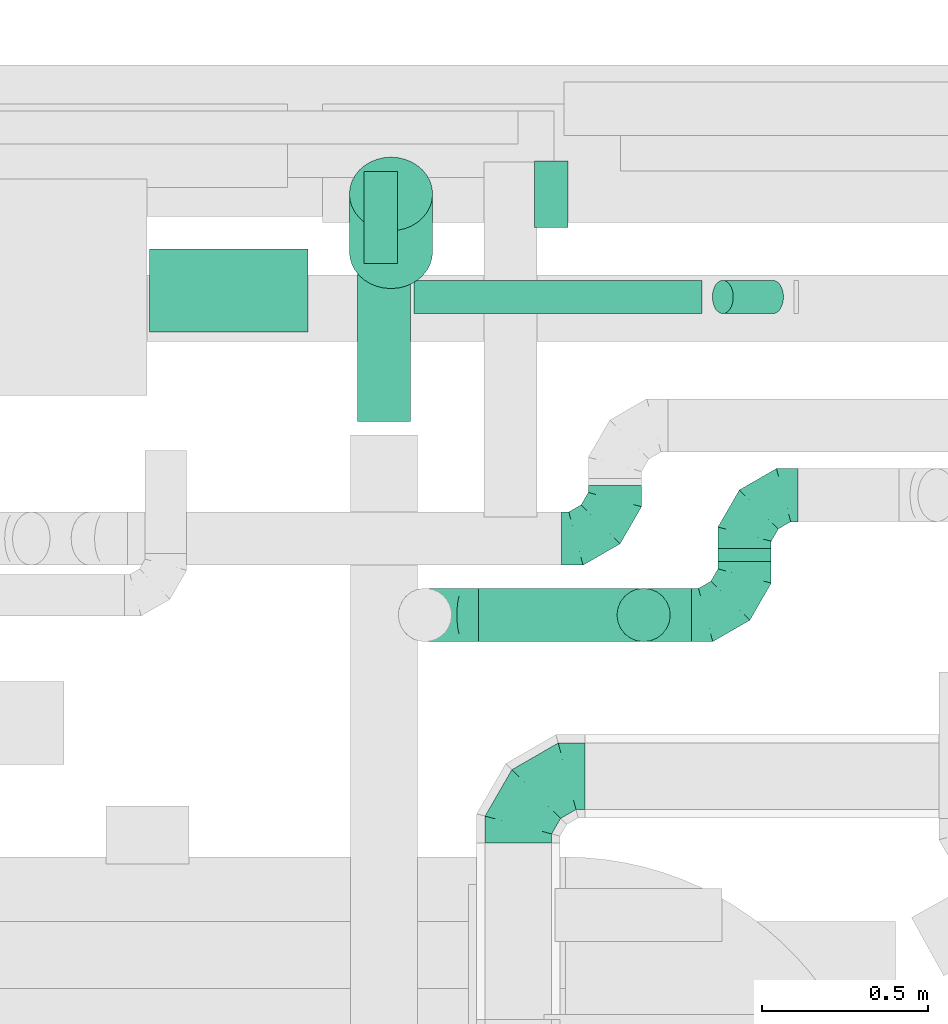
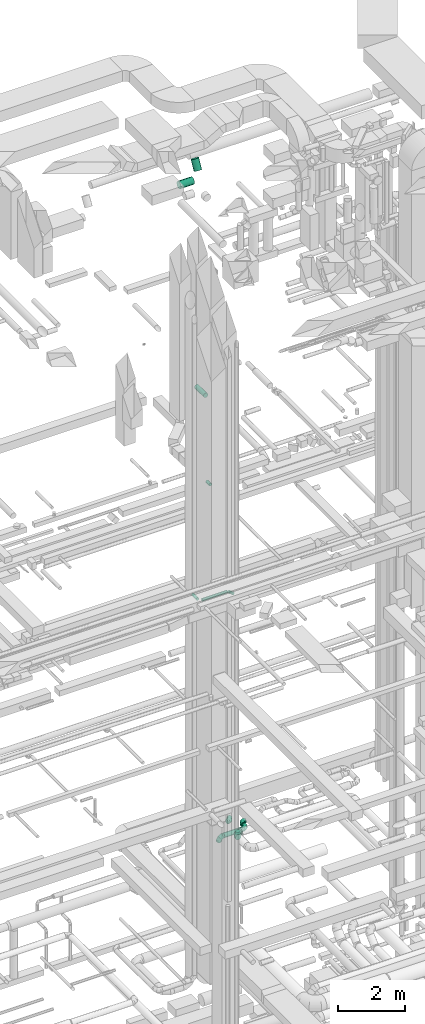
# One storey, part 281 of 337: 9 flow segments, 6 flow fittings.
"""IFC2X3 building model written with IfcOpenShell, lengths in millimetres."""

from ifc_helpers import new_model, entity, si_unit, converted_unit, derived_unit, direction, frame, origin, origin_2d_with_axis, place, context, subcontext, project, spatial, circle, extrude, faceted_brep, source, transform, mapped, material, type_object, type_shapes, element, save


model = new_model("IFC2X3")

# Units and contexts
model_context = context("Model", 3, precision=0.01, world=origin(), true_north=direction((6.12303176911189e-17, 1.0)))
body_context = subcontext(model_context, "Body", "Model", "MODEL_VIEW")
ifc_project = project(units=[si_unit("LENGTHUNIT", "METRE", prefix="MILLI"), si_unit("AREAUNIT", "SQUARE_METRE"), si_unit("VOLUMEUNIT", "CUBIC_METRE"), converted_unit("PLANEANGLEUNIT", "DEGREE", entity("IfcRatioMeasure", 0.0174532925199433), si_unit("PLANEANGLEUNIT", "RADIAN"), dimensions=[0, 0, 0, 0, 0, 0, 0]), si_unit("MASSUNIT", "GRAM", prefix="KILO"), derived_unit("MASSDENSITYUNIT", [(si_unit("MASSUNIT", "GRAM", prefix="KILO"), 1), (si_unit("LENGTHUNIT", "METRE"), -3)]), derived_unit("MOMENTOFINERTIAUNIT", [(si_unit("LENGTHUNIT", "METRE"), 4)]), si_unit("TIMEUNIT", "SECOND"), si_unit("FREQUENCYUNIT", "HERTZ"), si_unit("THERMODYNAMICTEMPERATUREUNIT", "DEGREE_CELSIUS"), derived_unit("THERMALTRANSMITTANCEUNIT", [(si_unit("MASSUNIT", "GRAM", prefix="KILO"), 1), (si_unit("THERMODYNAMICTEMPERATUREUNIT", "KELVIN"), -1), (si_unit("TIMEUNIT", "SECOND"), -3)]), derived_unit("VOLUMETRICFLOWRATEUNIT", [(si_unit("LENGTHUNIT", "METRE"), 3), (si_unit("TIMEUNIT", "SECOND"), -1)]), derived_unit("MASSFLOWRATEUNIT", [(si_unit("MASSUNIT", "GRAM", prefix="KILO"), 1), (si_unit("TIMEUNIT", "SECOND"), -1)]), derived_unit("ROTATIONALFREQUENCYUNIT", [(si_unit("TIMEUNIT", "SECOND"), -1)]), si_unit("ELECTRICCURRENTUNIT", "AMPERE"), si_unit("ELECTRICVOLTAGEUNIT", "VOLT"), si_unit("POWERUNIT", "WATT"), si_unit("FORCEUNIT", "NEWTON", prefix="KILO"), si_unit("ILLUMINANCEUNIT", "LUX"), si_unit("LUMINOUSFLUXUNIT", "LUMEN"), si_unit("LUMINOUSINTENSITYUNIT", "CANDELA"), derived_unit("USERDEFINED", [(si_unit("MASSUNIT", "GRAM", prefix="KILO"), -1), (si_unit("LENGTHUNIT", "METRE"), -2), (si_unit("TIMEUNIT", "SECOND"), 3), (si_unit("LUMINOUSFLUXUNIT", "LUMEN"), 1)]), derived_unit("LINEARVELOCITYUNIT", [(si_unit("LENGTHUNIT", "METRE"), 1), (si_unit("TIMEUNIT", "SECOND"), -1)]), si_unit("PRESSUREUNIT", "PASCAL"), derived_unit("USERDEFINED", [(si_unit("LENGTHUNIT", "METRE"), -2), (si_unit("MASSUNIT", "GRAM", prefix="KILO"), 1), (si_unit("TIMEUNIT", "SECOND"), -2)]), derived_unit("LINEARFORCEUNIT", [(si_unit("MASSUNIT", "GRAM", prefix="KILO"), 1), (si_unit("LENGTHUNIT", "METRE"), 1), (si_unit("TIMEUNIT", "SECOND"), -2), (si_unit("LENGTHUNIT", "METRE"), -1)]), derived_unit("PLANARFORCEUNIT", [(si_unit("MASSUNIT", "GRAM", prefix="KILO"), 1), (si_unit("LENGTHUNIT", "METRE"), 1), (si_unit("TIMEUNIT", "SECOND"), -2), (si_unit("LENGTHUNIT", "METRE"), -2)])], contexts=[model_context])

# Site, building, storey
site_placement = place(None, origin())
site = spatial("IfcSite", under=ifc_project, at=site_placement, CompositionType="ELEMENT")
building_placement = place(site_placement, origin())
building = spatial("IfcBuilding", under=site, at=building_placement, CompositionType="ELEMENT")
storey_placement = place(building_placement, origin())
storey = spatial("IfcBuildingStorey", under=building, at=storey_placement, CompositionType="ELEMENT", Elevation=0.0)

# Flow segments
duct_segment_type = type_object("IfcDuctSegmentType", PredefinedType="NOTDEFINED")
flow_segment_1_placement = place(storey_placement, frame((49059.87, 19353.19, 11348.4)))
element("IfcFlowSegment", 1, at=flow_segment_1_placement, inside=storey, type_object=duct_segment_type, context=body_context, shape_type="SweptSolid", body=[
    extrude(circle(Radius=50.0, at=origin_2d_with_axis()), frame((0.0, 51.6, 51.6), z_axis=(1.0, 0.0, 0.0), x_axis=(0.0, 1.0, 0.0)), (0.0, 0.0, 1.0), 864.588142746948),
])
flow_segment_2_placement = place(storey_placement, frame((49954.33, 19353.19, 11215.06)))
element("IfcFlowSegment", 2, at=flow_segment_2_placement, inside=storey, type_object=duct_segment_type, context=body_context, shape_type="SweptSolid", body=[
    extrude(circle(Radius=50.0, at=origin_2d_with_axis()), frame((33.06, 51.6, 162.65), z_axis=(0.777145961456967, 0.0, -0.629320391049843), x_axis=(0.0, -1.0, 0.0)), (0.0, 0.0, 1.0), 194.176285493916),
])
flow_segment_3_placement = place(storey_placement, frame((48908.27, 19504.79, 11348.4)))
element("IfcFlowSegment", 3, at=flow_segment_3_placement, inside=storey, type_object=duct_segment_type, context=body_context, shape_type="SweptSolid", body=[
    extrude(circle(Radius=50.0, at=origin_2d_with_axis()), frame((51.6, 0.0, 51.6), z_axis=(0.0, 1.0, 0.0), x_axis=(-1.0, 0.0, 0.0)), (0.0, 0.0, 1.0), 276.269796034324),
])
flow_segment_4_placement = place(storey_placement, frame((48888.15, 19030.52, 19073.4)))
element("IfcFlowSegment", 4, at=flow_segment_4_placement, inside=storey, type_object=duct_segment_type, context=body_context, shape_type="SweptSolid", body=[
    extrude(circle(Radius=80.0, at=origin_2d_with_axis()), frame((81.6, 0.0, 81.6), z_axis=(0.0, 1.0, 0.0), x_axis=(1.0, 0.0, 0.0)), (0.0, 0.0, 1.0), 539.99999999999),
])
flow_segment_5_placement = place(storey_placement, frame((49420.41, 19613.88, 15298.4)))
element("IfcFlowSegment", 5, at=flow_segment_5_placement, inside=storey, type_object=duct_segment_type, context=body_context, shape_type="SweptSolid", body=[
    extrude(circle(Radius=50.0, at=origin_2d_with_axis()), frame((51.6, 0.0, 51.6), z_axis=(0.0, 1.0, 0.0), x_axis=(-1.0, 0.0, 0.0)), (0.0, 0.0, 1.0), 200.000000000007),
])
flow_segment_6_placement = place(storey_placement, frame((49971.32, 18609.53, 3188.4)))
element("IfcFlowSegment", 6, at=flow_segment_6_placement, inside=storey, type_object=duct_segment_type, context=body_context, shape_type="SweptSolid", body=[
    extrude(circle(Radius=80.0, at=origin_2d_with_axis()), frame((81.6, 0.0, 81.6), z_axis=(0.0, 1.0, 0.0), x_axis=(-1.0, 0.0, 0.0)), (0.0, 0.0, 1.0), 40.0000000000169),
])
flow_segment_7_placement = place(storey_placement, frame((49252.92, 18367.93, 3188.4)))
element("IfcFlowSegment", 7, at=flow_segment_7_placement, inside=storey, type_object=duct_segment_type, context=body_context, shape_type="SweptSolid", body=[
    extrude(circle(Radius=80.0, at=origin_2d_with_axis()), frame((0.0, 81.6, 81.6), z_axis=(1.0, 0.0, 0.0), x_axis=(0.0, 1.0, 0.0)), (0.0, 0.0, 1.0), 639.999999999984),
])
flow_segment_8_placement = place(storey_placement, frame((48265.7, 19297.39, 26748.4)))
element("IfcFlowSegment", 8, at=flow_segment_8_placement, inside=storey, type_object=duct_segment_type, context=body_context, shape_type="SweptSolid", body=[
    extrude(circle(Radius=125.0, at=origin_2d_with_axis()), frame((0.0, 126.6, 126.6), z_axis=(1.0, 0.0, 0.0), x_axis=(0.0, 1.0, 0.0)), (0.0, 0.0, 1.0), 475.000000000005),
])
flow_segment_9_placement = place(storey_placement, frame((48864.11, 19428.49, 27036.19)))
element("IfcFlowSegment", 9, at=flow_segment_9_placement, inside=storey, type_object=duct_segment_type, context=body_context, shape_type="SweptSolid", body=[
    extrude(circle(Radius=125.0, at=origin_2d_with_axis()), frame((126.6, 112.15, 59.92), z_axis=(0.0, 0.46662609244127, 0.884454685019527), x_axis=(1.0, 0.0, 0.0)), (0.0, 0.0, 1.0), 372.214126997912),
])

# Flow fittings
ifc_material = material()
duct_fitting_type_1 = type_object("IfcDuctFittingType", PredefinedType="NOTDEFINED", material=ifc_material)
shared_shape_1 = source(origin(), body_context, "Body", "Brep", [
    faceted_brep([(-160.0, 0.0, -80.0), (-160.0, -20.71, -77.27), (-160.0, -40.0, -69.28), (-160.0, -56.57, -56.57), (-160.0, -69.28, -40.0), (-160.0, -77.27, -20.71), (-160.0, -80.0, 0.0), (-160.0, -77.27, 20.71), (-160.0, -69.28, 40.0), (-160.0, -56.57, 56.57), (-160.0, -40.0, 69.28), (-160.0, -20.71, 77.27), (-160.0, 0.0, 80.0), (-160.0, 20.71, 77.27), (-160.0, 40.0, 69.28), (-160.0, 56.57, 56.57), (-160.0, 69.28, 40.0), (-160.0, 77.27, 20.71), (-160.0, 80.0, 0.0), (-160.0, 77.27, -20.71), (-160.0, 69.28, -40.0), (-160.0, 56.57, -56.57), (-160.0, 40.0, -69.28), (-160.0, 20.71, -77.27), (-122.68, 20.71, 77.27), (-127.85, 40.0, 69.28), (-117.13, 0.0, 80.0), (-132.29, 56.57, 56.57), (-137.83, 77.27, 20.71), (-138.56, 80.0, 0.0), (-135.69, 69.28, 40.0), (-135.69, 69.28, -40.0), (-132.29, 56.57, -56.57), (-137.83, 77.27, -20.71), (-122.68, 20.71, -77.27), (-117.13, 0.0, -80.0), (-127.85, 40.0, -69.28), (-111.58, -20.71, -77.27), (-106.41, -40.0, -69.28), (-101.97, -56.57, -56.57), (-98.56, -69.28, -40.0), (-96.42, -77.27, -20.71), (-95.69, -80.0, 0.0), (-96.42, -77.27, 20.71), (-98.56, -69.28, 40.0), (-101.97, -56.57, 56.57), (-106.41, -40.0, 69.28), (-111.58, -20.71, 77.27), (-58.03, 58.03, 77.27), (-72.15, 72.15, 69.28), (-42.87, 42.87, 80.0), (-84.28, 84.28, 56.57), (-93.59, 93.59, 40.0), (-99.44, 99.44, 20.71), (-101.44, 101.44, 0.0), (-99.44, 99.44, -20.71), (-93.59, 93.59, -40.0), (-84.28, 84.28, -56.57), (-58.03, 58.03, -77.27), (-42.87, 42.87, -80.0), (-72.15, 72.15, -69.28), (-27.71, 27.71, -77.27), (-13.59, 13.59, -69.28), (-1.46, 1.46, -56.57), (7.85, -7.85, -40.0), (13.7, -13.7, -20.71), (15.69, -15.69, 0.0), (13.7, -13.7, 20.71), (7.85, -7.85, 40.0), (-1.46, 1.46, 56.57), (-13.59, 13.59, 69.28), (-27.71, 27.71, 77.27), (-20.71, 122.68, 77.27), (-40.0, 127.85, 69.28), (0.0, 117.13, 80.0), (-56.57, 132.29, 56.57), (-69.28, 135.69, 40.0), (-77.27, 137.83, 20.71), (-80.0, 138.56, 0.0), (-77.27, 137.83, -20.71), (-69.28, 135.69, -40.0), (-56.57, 132.29, -56.57), (-20.71, 122.68, -77.27), (0.0, 117.13, -80.0), (-40.0, 127.85, -69.28), (20.71, 111.58, -77.27), (40.0, 106.41, -69.28), (56.57, 101.97, -56.57), (69.28, 98.56, -40.0), (77.27, 96.42, -20.71), (80.0, 95.69, 0.0), (77.27, 96.42, 20.71), (69.28, 98.56, 40.0), (56.57, 101.97, 56.57), (40.0, 106.41, 69.28), (20.71, 111.58, 77.27), (-20.71, 160.0, -77.27), (-40.0, 160.0, -69.28), (-56.57, 160.0, -56.57), (-69.28, 160.0, -40.0), (-77.27, 160.0, -20.71), (-80.0, 160.0, 0.0), (-77.27, 160.0, 20.71), (-69.28, 160.0, 40.0), (-56.57, 160.0, 56.57), (-40.0, 160.0, 69.28), (-20.71, 160.0, 77.27), (0.0, 160.0, 80.0), (20.71, 160.0, 77.27), (40.0, 160.0, 69.28), (56.57, 160.0, 56.57), (69.28, 160.0, 40.0), (77.27, 160.0, 20.71), (80.0, 160.0, 0.0), (77.27, 160.0, -20.71), (69.28, 160.0, -40.0), (56.57, 160.0, -56.57), (40.0, 160.0, -69.28), (20.71, 160.0, -77.27), (0.0, 160.0, -80.0)], [[[0, 1, 2, 3, 4, 5, 6, 7, 8, 9, 10, 11, 12, 13, 14, 15, 16, 17, 18, 19, 20, 21, 22, 23]], [[24, 25, 14, 13]], [[26, 24, 13, 12]], [[14, 25, 27, 15]], [[28, 29, 18, 17]], [[30, 28, 17, 16]], [[15, 27, 30, 16]], [[20, 31, 32, 21]], [[33, 31, 20, 19]], [[18, 29, 33, 19]], [[34, 35, 0, 23]], [[36, 34, 23, 22]], [[32, 36, 22, 21]], [[1, 0, 35, 37]], [[2, 1, 37, 38]], [[3, 2, 38, 39]], [[5, 4, 40, 41]], [[6, 5, 41, 42]], [[39, 40, 4, 3]], [[6, 42, 43, 7]], [[7, 43, 44, 8]], [[8, 44, 45, 9]], [[9, 45, 46, 10]], [[10, 46, 47, 11]], [[26, 12, 11, 47]], [[48, 49, 25, 24]], [[50, 48, 24, 26]], [[27, 25, 49, 51]], [[52, 53, 28, 30]], [[51, 52, 30, 27]], [[29, 28, 53, 54]], [[55, 56, 31, 33]], [[54, 55, 33, 29]], [[32, 31, 56, 57]], [[58, 59, 35, 34]], [[60, 58, 34, 36]], [[57, 60, 36, 32]], [[37, 35, 59, 61]], [[38, 37, 61, 62]], [[39, 38, 62, 63]], [[41, 40, 64, 65]], [[42, 41, 65, 66]], [[63, 64, 40, 39]], [[43, 42, 66, 67]], [[44, 43, 67, 68]], [[68, 69, 45, 44]], [[46, 45, 69, 70]], [[47, 46, 70, 71]], [[26, 47, 71, 50]], [[72, 73, 49, 48]], [[74, 72, 48, 50]], [[51, 49, 73, 75]], [[76, 77, 53, 52]], [[75, 76, 52, 51]], [[54, 53, 77, 78]], [[79, 80, 56, 55]], [[78, 79, 55, 54]], [[57, 56, 80, 81]], [[82, 83, 59, 58]], [[84, 82, 58, 60]], [[81, 84, 60, 57]], [[61, 59, 83, 85]], [[62, 61, 85, 86]], [[63, 62, 86, 87]], [[65, 64, 88, 89]], [[66, 65, 89, 90]], [[87, 88, 64, 63]], [[67, 66, 90, 91]], [[68, 67, 91, 92]], [[92, 93, 69, 68]], [[70, 69, 93, 94]], [[71, 70, 94, 95]], [[50, 71, 95, 74]], [[96, 97, 98, 99, 100, 101, 102, 103, 104, 105, 106, 107, 108, 109, 110, 111, 112, 113, 114, 115, 116, 117, 118, 119]], [[72, 74, 107, 106]], [[73, 72, 106, 105]], [[75, 73, 105, 104]], [[77, 76, 103, 102]], [[78, 77, 102, 101]], [[75, 104, 103, 76]], [[78, 101, 100, 79]], [[79, 100, 99, 80]], [[80, 99, 98, 81]], [[84, 97, 96, 82]], [[82, 96, 119, 83]], [[84, 81, 98, 97]], [[118, 117, 86, 85]], [[119, 118, 85, 83]], [[116, 87, 86, 117]], [[88, 115, 114, 89]], [[89, 114, 113, 90]], [[115, 88, 87, 116]], [[112, 111, 92, 91]], [[113, 112, 91, 90]], [[111, 110, 93, 92]], [[95, 94, 109, 108]], [[74, 95, 108, 107]], [[110, 109, 94, 93]]]),
])
type_shapes(duct_fitting_type_1, [shared_shape_1])
for number, where in (
    (10, (49663.34, 18679.11, 3550.0)),
    (11, (50052.92, 18449.53, 3270.0)),
):
    element("IfcFlowFitting", number, at=place(storey_placement, frame(where)), inside=storey, type_object=duct_fitting_type_1, material=ifc_material, context=body_context, shape_type="MappedRepresentation", body=[
        mapped(shared_shape_1, transform((0.0, 0.0, 0.0), scale=1.0)),
    ])
for number, where, z_axis, x_axis in (
    (12, (50052.92, 18809.53, 3270.0), (0.0, 0.0, 1.0), (-1.0, 0.0, 0.0)),
    (13, (49092.92, 18449.53, 3270.0), (0.0, -1.0, 0.0), (-1.0, 0.0, 0.0)),
):
    element("IfcFlowFitting", number, at=place(storey_placement, frame(where, z_axis=z_axis, x_axis=x_axis)), inside=storey, type_object=duct_fitting_type_1, material=ifc_material, context=body_context, shape_type="MappedRepresentation", body=[
        mapped(shared_shape_1, transform((0.0, 0.0, 0.0), scale=1.0)),
    ])
duct_fitting_type_2 = type_object("IfcDuctFittingType", PredefinedType="NOTDEFINED", material=ifc_material)
shared_shape_2 = source(origin(), body_context, "Body", "Brep", [
    faceted_brep([(-200.0, 0.0, -100.0), (-200.0, -25.88, -96.59), (-200.0, -50.0, -86.6), (-200.0, -70.71, -70.71), (-200.0, -86.6, -50.0), (-200.0, -96.59, -25.88), (-200.0, -100.0, 0.0), (-200.0, -96.59, 25.88), (-200.0, -86.6, 50.0), (-200.0, -70.71, 70.71), (-200.0, -50.0, 86.6), (-200.0, -25.88, 96.59), (-200.0, 0.0, 100.0), (-200.0, 25.88, 96.59), (-200.0, 50.0, 86.6), (-200.0, 70.71, 70.71), (-200.0, 86.6, 50.0), (-200.0, 96.59, 25.88), (-200.0, 100.0, 0.0), (-200.0, 96.59, -25.88), (-200.0, 86.6, -50.0), (-200.0, 70.71, -70.71), (-200.0, 50.0, -86.6), (-200.0, 25.88, -96.59), (-153.35, 25.88, 96.59), (-159.81, 50.0, 86.6), (-146.41, 0.0, 100.0), (-165.36, 70.71, 70.71), (-172.29, 96.59, 25.88), (-173.21, 100.0, 0.0), (-169.62, 86.6, 50.0), (-169.62, 86.6, -50.0), (-165.36, 70.71, -70.71), (-172.29, 96.59, -25.88), (-153.35, 25.88, -96.59), (-146.41, 0.0, -100.0), (-159.81, 50.0, -86.6), (-139.48, -25.88, -96.59), (-133.01, -50.0, -86.6), (-127.46, -70.71, -70.71), (-123.21, -86.6, -50.0), (-120.53, -96.59, -25.88), (-119.62, -100.0, 0.0), (-120.53, -96.59, 25.88), (-123.21, -86.6, 50.0), (-127.46, -70.71, 70.71), (-133.01, -50.0, 86.6), (-139.48, -25.88, 96.59), (-72.54, 72.54, 96.59), (-90.19, 90.19, 86.6), (-53.59, 53.59, 100.0), (-105.35, 105.35, 70.71), (-116.99, 116.99, 50.0), (-124.3, 124.3, 25.88), (-126.79, 126.79, 0.0), (-124.3, 124.3, -25.88), (-116.99, 116.99, -50.0), (-105.35, 105.35, -70.71), (-72.54, 72.54, -96.59), (-53.59, 53.59, -100.0), (-90.19, 90.19, -86.6), (-34.64, 34.64, -96.59), (-16.99, 16.99, -86.6), (-1.83, 1.83, -70.71), (9.81, -9.81, -50.0), (17.12, -17.12, -25.88), (19.62, -19.62, 0.0), (17.12, -17.12, 25.88), (9.81, -9.81, 50.0), (-1.83, 1.83, 70.71), (-16.99, 16.99, 86.6), (-34.64, 34.64, 96.59), (-25.88, 153.35, 96.59), (-50.0, 159.81, 86.6), (0.0, 146.41, 100.0), (-70.71, 165.36, 70.71), (-86.6, 169.62, 50.0), (-96.59, 172.29, 25.88), (-100.0, 173.21, 0.0), (-96.59, 172.29, -25.88), (-86.6, 169.62, -50.0), (-70.71, 165.36, -70.71), (-25.88, 153.35, -96.59), (0.0, 146.41, -100.0), (-50.0, 159.81, -86.6), (25.88, 139.48, -96.59), (50.0, 133.01, -86.6), (70.71, 127.46, -70.71), (86.6, 123.21, -50.0), (96.59, 120.53, -25.88), (100.0, 119.62, 0.0), (96.59, 120.53, 25.88), (86.6, 123.21, 50.0), (70.71, 127.46, 70.71), (50.0, 133.01, 86.6), (25.88, 139.48, 96.59), (-25.88, 200.0, -96.59), (-50.0, 200.0, -86.6), (-70.71, 200.0, -70.71), (-86.6, 200.0, -50.0), (-96.59, 200.0, -25.88), (-100.0, 200.0, 0.0), (-96.59, 200.0, 25.88), (-86.6, 200.0, 50.0), (-70.71, 200.0, 70.71), (-50.0, 200.0, 86.6), (-25.88, 200.0, 96.59), (0.0, 200.0, 100.0), (25.88, 200.0, 96.59), (50.0, 200.0, 86.6), (70.71, 200.0, 70.71), (86.6, 200.0, 50.0), (96.59, 200.0, 25.88), (100.0, 200.0, 0.0), (96.59, 200.0, -25.88), (86.6, 200.0, -50.0), (70.71, 200.0, -70.71), (50.0, 200.0, -86.6), (25.88, 200.0, -96.59), (0.0, 200.0, -100.0)], [[[0, 1, 2, 3, 4, 5, 6, 7, 8, 9, 10, 11, 12, 13, 14, 15, 16, 17, 18, 19, 20, 21, 22, 23]], [[24, 25, 14, 13]], [[26, 24, 13, 12]], [[14, 25, 27, 15]], [[28, 29, 18, 17]], [[30, 28, 17, 16]], [[15, 27, 30, 16]], [[20, 31, 32, 21]], [[33, 31, 20, 19]], [[18, 29, 33, 19]], [[34, 35, 0, 23]], [[36, 34, 23, 22]], [[32, 36, 22, 21]], [[1, 0, 35, 37]], [[2, 1, 37, 38]], [[38, 39, 3, 2]], [[5, 4, 40, 41]], [[6, 5, 41, 42]], [[39, 40, 4, 3]], [[6, 42, 43, 7]], [[7, 43, 44, 8]], [[8, 44, 45, 9]], [[9, 45, 46, 10]], [[10, 46, 47, 11]], [[26, 12, 11, 47]], [[48, 49, 25, 24]], [[50, 48, 24, 26]], [[27, 25, 49, 51]], [[52, 53, 28, 30]], [[51, 52, 30, 27]], [[29, 28, 53, 54]], [[55, 56, 31, 33]], [[54, 55, 33, 29]], [[32, 31, 56, 57]], [[58, 59, 35, 34]], [[60, 58, 34, 36]], [[57, 60, 36, 32]], [[37, 35, 59, 61]], [[38, 37, 61, 62]], [[39, 38, 62, 63]], [[41, 40, 64, 65]], [[42, 41, 65, 66]], [[63, 64, 40, 39]], [[43, 42, 66, 67]], [[44, 43, 67, 68]], [[68, 69, 45, 44]], [[46, 45, 69, 70]], [[47, 46, 70, 71]], [[26, 47, 71, 50]], [[72, 73, 49, 48]], [[74, 72, 48, 50]], [[51, 49, 73, 75]], [[76, 77, 53, 52]], [[75, 76, 52, 51]], [[54, 53, 77, 78]], [[79, 80, 56, 55]], [[78, 79, 55, 54]], [[57, 56, 80, 81]], [[82, 83, 59, 58]], [[84, 82, 58, 60]], [[81, 84, 60, 57]], [[61, 59, 83, 85]], [[62, 61, 85, 86]], [[63, 62, 86, 87]], [[65, 64, 88, 89]], [[66, 65, 89, 90]], [[87, 88, 64, 63]], [[67, 66, 90, 91]], [[68, 67, 91, 92]], [[92, 93, 69, 68]], [[70, 69, 93, 94]], [[71, 70, 94, 95]], [[50, 71, 95, 74]], [[96, 97, 98, 99, 100, 101, 102, 103, 104, 105, 106, 107, 108, 109, 110, 111, 112, 113, 114, 115, 116, 117, 118, 119]], [[72, 74, 107, 106]], [[73, 72, 106, 105]], [[75, 73, 105, 104]], [[102, 101, 78, 77]], [[103, 102, 77, 76]], [[75, 104, 103, 76]], [[78, 101, 100, 79]], [[79, 100, 99, 80]], [[80, 99, 98, 81]], [[84, 97, 96, 82]], [[82, 96, 119, 83]], [[84, 81, 98, 97]], [[118, 117, 86, 85]], [[119, 118, 85, 83]], [[116, 87, 86, 117]], [[88, 115, 114, 89]], [[89, 114, 113, 90]], [[115, 88, 87, 116]], [[91, 90, 113, 112]], [[92, 91, 112, 111]], [[111, 110, 93, 92]], [[95, 94, 109, 108]], [[74, 95, 108, 107]], [[110, 109, 94, 93]]]),
])
type_shapes(duct_fitting_type_2, [shared_shape_2])
flow_fitting_1_placement = place(storey_placement, frame((49373.27, 17965.07, 3580.0), z_axis=(0.0, 0.0, 1.0), x_axis=(-1.0, 0.0, 0.0)))
element("IfcFlowFitting", 14, at=flow_fitting_1_placement, inside=storey, type_object=duct_fitting_type_2, material=ifc_material, context=body_context, shape_type="MappedRepresentation", body=[
    mapped(shared_shape_2, transform((0.0, 0.0, 0.0), scale=1.0)),
])
duct_fitting_type_3 = type_object("IfcDuctFittingType", PredefinedType="NOTDEFINED", material=ifc_material)
shared_shape_3 = source(origin(), body_context, "Body", "Brep", [
    faceted_brep([(20.0, 0.0, -80.0), (20.0, 20.71, -77.27), (20.0, 40.0, -69.28), (20.0, 56.57, -56.57), (20.0, 69.28, -40.0), (20.0, 77.27, -20.71), (20.0, 80.0, 0.0), (20.0, 77.27, 20.71), (20.0, 69.28, 40.0), (20.0, 56.57, 56.57), (20.0, 40.0, 69.28), (20.0, 20.71, 77.27), (20.0, 0.0, 80.0), (20.0, -20.71, 77.27), (20.0, -40.0, 69.28), (20.0, -56.57, 56.57), (20.0, -69.28, 40.0), (20.0, -77.27, 20.71), (20.0, -80.0, 0.0), (20.0, -77.27, -20.71), (20.0, -69.28, -40.0), (20.0, -56.57, -56.57), (20.0, -40.0, -69.28), (20.0, -20.71, -77.27), (0.0, 0.0, 80.0), (-73.9, 0.0, 80.0), (-73.9, -20.71, 77.27), (0.0, -20.71, 77.27), (-73.9, -40.0, 69.28), (0.0, -40.0, 69.28), (0.0, -56.57, 56.57), (-73.9, -56.57, 56.57), (0.0, -69.28, 40.0), (-73.9, -69.28, 40.0), (-73.9, -77.27, 20.71), (0.0, -77.27, 20.71), (-73.9, -80.0, 0.0), (0.0, -80.0, 0.0), (-73.9, -77.27, -20.71), (0.0, -77.27, -20.71), (-73.9, -69.28, -40.0), (0.0, -69.28, -40.0), (0.0, -56.57, -56.57), (-73.9, -56.57, -56.57), (0.0, -40.0, -69.28), (-73.9, -40.0, -69.28), (-73.9, -20.71, -77.27), (0.0, -20.71, -77.27), (-73.9, 0.0, -80.0), (0.0, 0.0, -80.0), (-73.9, 20.71, -77.27), (0.0, 20.71, -77.27), (-73.9, 40.0, -69.28), (0.0, 40.0, -69.28), (0.0, 56.57, -56.57), (-73.9, 56.57, -56.57), (0.0, 69.28, -40.0), (-73.9, 69.28, -40.0), (-73.9, 77.27, -20.71), (0.0, 77.27, -20.71), (-73.9, 80.0, 0.0), (0.0, 80.0, 0.0), (-73.9, 77.27, 20.71), (0.0, 77.27, 20.71), (-73.9, 69.28, 40.0), (0.0, 69.28, 40.0), (0.0, 56.57, 56.57), (-73.9, 56.57, 56.57), (0.0, 40.0, 69.28), (-73.9, 40.0, 69.28), (-73.9, 20.71, 77.27), (0.0, 20.71, 77.27)], [[[0, 1, 2, 3, 4, 5, 6, 7, 8, 9, 10, 11, 12, 13, 14, 15, 16, 17, 18, 19, 20, 21, 22, 23]], [[13, 12, 24, 25, 26, 27]], [[14, 13, 27, 26, 28, 29]], [[30, 15, 14, 29, 28, 31]], [[17, 16, 32, 33, 34, 35]], [[18, 17, 35, 34, 36, 37]], [[32, 16, 15, 30, 31, 33]], [[19, 18, 37, 36, 38, 39]], [[20, 19, 39, 38, 40, 41]], [[42, 21, 20, 41, 40, 43]], [[23, 22, 44, 45, 46, 47]], [[0, 23, 47, 46, 48, 49]], [[44, 22, 21, 42, 43, 45]], [[1, 0, 49, 48, 50, 51]], [[2, 1, 51, 50, 52, 53]], [[54, 3, 2, 53, 52, 55]], [[5, 4, 56, 57, 58, 59]], [[6, 5, 59, 58, 60, 61]], [[56, 4, 3, 54, 55, 57]], [[7, 6, 61, 60, 62, 63]], [[8, 7, 63, 62, 64, 65]], [[66, 9, 8, 65, 64, 67]], [[11, 10, 68, 69, 70, 71]], [[12, 11, 71, 70, 25, 24]], [[68, 10, 9, 66, 67, 69]], [[46, 45, 43, 40, 38, 36, 34, 33, 31, 28, 26, 25, 70, 69, 67, 64, 62, 60, 58, 57, 55, 52, 50, 48]]]),
])
type_shapes(duct_fitting_type_3, [shared_shape_3])
flow_fitting_2_placement = place(storey_placement, frame((49749.57, 18449.53, 3190.0), z_axis=(1.0, 0.0, 0.0), x_axis=(0.0, 0.0, -1.0)))
element("IfcFlowFitting", 15, at=flow_fitting_2_placement, inside=storey, type_object=duct_fitting_type_3, material=ifc_material, context=body_context, shape_type="MappedRepresentation", body=[
    mapped(shared_shape_3, transform((0.0, 0.0, 0.0), scale=1.0)),
])

save(model, "model.ifc")
